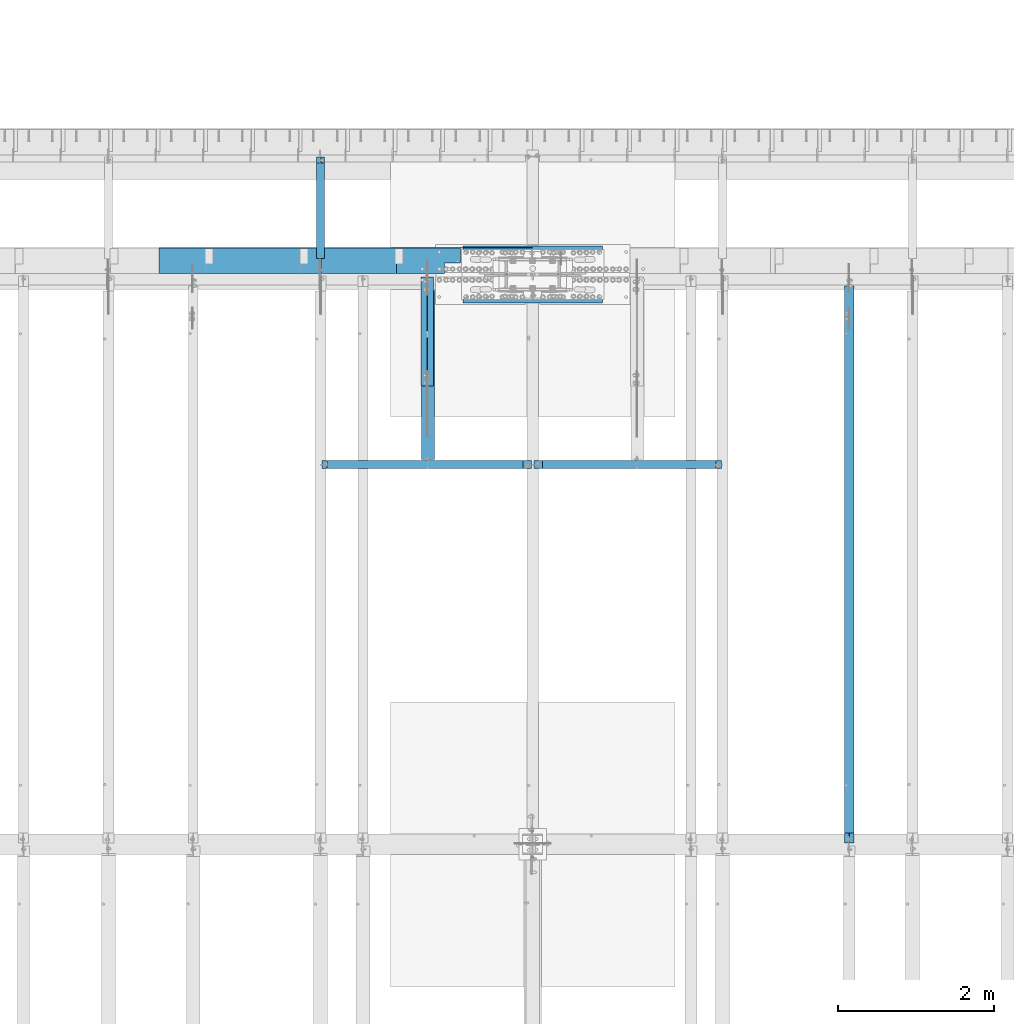
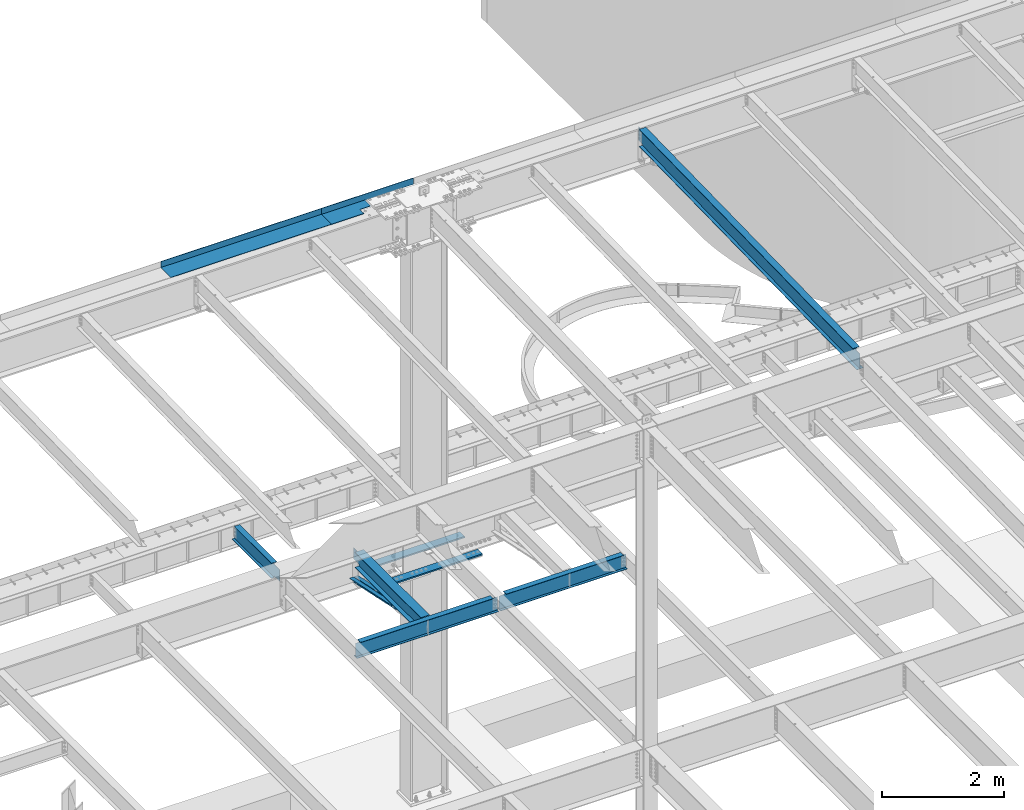
# One storey, part 1132 of 1763: 11 beams, 8 elements without a shape of their own.
"""IFC2X3 building model written with IfcOpenShell, lengths in millimetres."""

from ifc_helpers import new_model, si_unit, frame, origin_with_axes, place, context, subcontext, project, spatial, faceted_brep, material, type_object, element, aggregate, save


model = new_model("IFC2X3")

# Units and contexts
model_context = context("Model", 3, precision=1e-05, world=origin_with_axes())
body_context = subcontext(model_context, "Body", "Model", "MODEL_VIEW")
ifc_project = project(units=[si_unit("LENGTHUNIT", "METRE", prefix="MILLI"), si_unit("AREAUNIT", "SQUARE_METRE"), si_unit("VOLUMEUNIT", "CUBIC_METRE"), si_unit("MASSUNIT", "GRAM", prefix="KILO"), si_unit("TIMEUNIT", "SECOND"), si_unit("PLANEANGLEUNIT", "RADIAN"), si_unit("SOLIDANGLEUNIT", "STERADIAN"), si_unit("THERMODYNAMICTEMPERATUREUNIT", "DEGREE_CELSIUS"), si_unit("LUMINOUSINTENSITYUNIT", "LUMEN")], contexts=[model_context])

# Site, building, storey
site_placement = place(None, origin_with_axes())
site = spatial("IfcSite", under=ifc_project, at=site_placement, CompositionType="ELEMENT")
building_placement = place(site_placement, origin_with_axes())
building = spatial("IfcBuilding", under=site, at=building_placement, Name="Undefined", CompositionType="ELEMENT")
storey_placement = place(building_placement, origin_with_axes())
storey = spatial("IfcBuildingStorey", under=building, at=storey_placement, Name="Undefined", CompositionType="ELEMENT", Elevation=0.0)

# Assembly, beams
assembly_1_placement = place(storey_placement, origin_with_axes())
assembly_1 = element("IfcElementAssembly", 1, at=assembly_1_placement, inside=storey, Name="COLUMN", AssemblyPlace="NOTDEFINED", PredefinedType="RIGID_FRAME")
ifc_material_1 = material(Name="STEEL/A572-50")
beam_type_1 = type_object("IfcBeamType", PredefinedType="NOTDEFINED")
beam_1_placement = place(assembly_1_placement, frame((-60697.4997736983, 52409.725, 4433.8875), z_axis=(0.0, -1.0, 0.0), x_axis=(-1.0, 0.0, 0.0)))
beam_1 = element("IfcBeam", 2, at=beam_1_placement, type_object=beam_type_1, material=ifc_material_1, Name="PLATE", context=body_context, shape_type="Brep", body=[
    faceted_brep([(0.0, 14.2875000000004, -79.375), (0.0, 14.2875000000004, 79.375), (1793.875, 14.2875000000004, 79.375), (1793.875, 14.2875000000004, -79.375), (0.0, -14.2875000000004, 79.375), (1793.875, -14.2875000000004, 79.375), (0.0, -14.2875000000004, -79.375), (1793.875, -14.2875000000004, -79.375)], [[[0, 1, 2, 3]], [[1, 4, 5, 2]], [[4, 6, 7, 5]], [[6, 0, 3, 7]], [[5, 7, 3, 2]], [[6, 4, 1, 0]]]),
])
beam_2_placement = place(assembly_1_placement, frame((-60697.4997736983, 51831.875, 4433.8875), z_axis=(0.0, -1.0, 0.0), x_axis=(-1.0, 0.0, 0.0)))
beam_2 = element("IfcBeam", 3, at=beam_2_placement, type_object=beam_type_1, material=ifc_material_1, Name="PLATE", context=body_context, shape_type="Brep", body=[
    faceted_brep([(0.0, 14.2875000000004, -79.375), (0.0, 14.2875000000004, 79.375), (1793.875, 14.2875000000004, 79.375), (1793.875, 14.2875000000004, -79.375), (0.0, -14.2875000000004, 79.375), (1793.875, -14.2875000000004, 79.375), (0.0, -14.2875000000004, -79.375), (1793.875, -14.2875000000004, -79.375)], [[[0, 1, 2, 3]], [[1, 4, 5, 2]], [[4, 6, 7, 5]], [[6, 0, 3, 7]], [[5, 7, 3, 2]], [[6, 4, 1, 0]]]),
])
aggregate(assembly_1, [beam_1, beam_2])

# Assembly, beam
assembly_2_placement = place(storey_placement, origin_with_axes())
assembly_2 = element("IfcElementAssembly", 4, at=assembly_2_placement, inside=storey, Name="BEAM", AssemblyPlace="NOTDEFINED", PredefinedType="RIGID_FRAME")
ifc_material_2 = material(Name="STEEL/A992")
beam_type_2 = type_object("IfcBeamType", Name="W14X22", PredefinedType="NOTDEFINED")
beam_3_placement = place(assembly_2_placement, frame((-57530.4372736983, 44809.2121579121, 11421.5633921212), z_axis=(0.0, -0.0206852279954837, 0.999786037781472), x_axis=(0.0, 0.999786037781472, 0.0206852279954825)))
beam_3 = element("IfcBeam", 5, at=beam_3_placement, type_object=beam_type_2, material=ifc_material_2, Name="BEAM", ObjectType="W14X22", context=body_context, shape_type="Brep", body=[
    faceted_brep([(7162.77359555585, -3.17500000000291, -166.687500001777), (7162.77359555585, -63.5, -166.687500001777), (7162.77359555585, -63.5, -174.625000001772), (7162.77359555585, 63.5, -174.625000001772), (7162.77359555585, 63.5, -166.687500001777), (7162.77359555585, 3.17500000000291, -166.687500001777), (7162.77359555586, 3.17500000000291, -155.574999838074), (7162.77359555586, -3.17500000000291, -155.574999838074), (7163.74032547845, 3.17500000000291, -150.714920320039), (7163.74032547845, -3.17500000000291, -150.714920320039), (7166.49333937895, 3.17500000000291, -146.594743851894), (7166.49333937895, -3.17500000000291, -146.594743851894), (7170.61351584714, 3.17500000000291, -143.841729951426), (7170.61351584714, -3.17500000000291, -143.841729951426), (7175.47359536523, 3.17500000000291, -142.87500002884), (7175.47359536523, -3.17500000000291, -142.87500002884), (7289.55462988591, -3.17500000000291, -142.875000028898), (7289.55462988591, 3.17500000000291, -142.875000028898), (148.791145859177, 3.17500000000291, 166.687499999833), (148.791145859177, 63.5, 166.687499999833), (7169.123595556, 63.5, 166.68749999797), (7169.123595556, 3.17500000000291, 166.68749999797), (11.9924390219312, 3.17500000000291, -166.687499999878), (11.9924390219312, 63.5, -166.687499999878), (11.8282148869548, 63.5, -174.624999999871), (11.8282148869548, -63.5, -174.624999999871), (11.9924390219312, -63.5, -166.687499999878), (11.9924390219312, -3.17500000000291, -166.687499999878), (17.9976630864912, -3.17500000000291, 123.56500167838), (17.9976630864912, 3.17500000000291, 123.56500167838), (136.091146049795, -3.17500000000291, 123.565001678358), (136.091146049795, 3.17500000000291, 123.565001678358), (140.951225567893, -3.17500000000291, 124.531731600942), (140.951225567893, 3.17500000000291, 124.531731600942), (145.071402036083, -3.17500000000291, 127.284745501414), (145.071402036083, 3.17500000000291, 127.284745501414), (147.824415936586, -3.17500000000291, 131.404921969557), (147.824415936586, 3.17500000000291, 131.404921969557), (148.791145859177, -3.17500000000291, 136.265001487593), (148.791145859177, 3.17500000000291, 136.265001487593), (148.79114585917, -63.5, 174.624999999827), (148.79114585917, 63.5, 174.624999999827), (148.791145859177, -3.17500000000291, 166.687499999833), (148.791145859177, -63.5, 166.687499999833), (7169.123595556, -3.17500000000291, 166.68749999797), (7169.123595556, -63.5, 166.68749999797), (7169.123595556, -63.5, 174.624999997965), (7169.123595556, 63.5, 174.624999997965), (7169.123595556, -3.17500000000291, 142.875000542512), (7169.123595556, 3.17500000000291, 142.875000542512), (7170.0903254786, -3.17500000000291, 138.014921024478), (7170.0903254786, 3.17500000000291, 138.014921024478), (7172.8433393791, -3.17500000000291, 133.894744556334), (7172.8433393791, 3.17500000000291, 133.894744556334), (7176.96351584728, -3.17500000000291, 131.14173065586), (7176.96351584728, 3.17500000000291, 131.14173065586), (7181.82359536537, -3.17500000000291, 130.175000733272), (7181.82359536537, 3.17500000000291, 130.175000733272), (7295.20394014482, -3.17500000000291, 130.17500073325), (7295.20394014482, 3.17500000000291, 130.17500073325)], [[[0, 1, 2, 3, 4, 5, 6, 7]], [[7, 6, 8, 9]], [[9, 8, 10, 11]], [[11, 10, 12, 13]], [[13, 12, 14, 15]], [[16, 15, 14, 17]], [[18, 19, 20, 21]], [[22, 23, 24, 25, 26, 27, 28, 29]], [[30, 31, 29, 28]], [[32, 33, 31, 30]], [[34, 35, 33, 32]], [[36, 37, 35, 34]], [[38, 39, 37, 36]], [[40, 41, 19, 18, 39, 38, 42, 43]], [[43, 42, 44, 45]], [[40, 43, 45, 46]], [[41, 40, 46, 47]], [[19, 41, 47, 20]], [[46, 45, 44, 48, 49, 21, 20, 47]], [[50, 51, 49, 48]], [[52, 53, 51, 50]], [[54, 55, 53, 52]], [[56, 57, 55, 54]], [[58, 59, 57, 56]], [[59, 58, 16, 17]], [[12, 10, 8, 6, 5, 22, 29, 31, 33, 35, 37, 39, 18, 21, 49, 51, 53, 55, 57, 59, 17, 14]], [[23, 22, 5, 4]], [[24, 23, 4, 3]], [[25, 24, 3, 2]], [[26, 25, 2, 1]], [[27, 26, 1, 0]], [[58, 56, 54, 52, 50, 48, 44, 42, 38, 36, 34, 32, 30, 28, 27, 0, 7, 9, 11, 13, 15, 16]]]),
])
aggregate(assembly_2, [beam_3])

# Assembly, beams
assembly_3_placement = place(storey_placement, origin_with_axes())
assembly_3 = element("IfcElementAssembly", 6, at=assembly_3_placement, inside=storey, Name="ANGLE BRACE", AssemblyPlace="NOTDEFINED", PredefinedType="RIGID_FRAME")
ifc_material_3 = material(Name="STEEL/A36")
beam_type_3 = type_object("IfcBeamType", Name="L4X3X5/16", PredefinedType="NOTDEFINED")
beam_4_placement = place(assembly_3_placement, frame((-62991.4372736984, 50680.4564530846, 4820.75267554856), z_axis=(0.0, -0.2072236520035, -0.978293595016513), x_axis=(0.0, 0.978293600950479, -0.20722362398951)))
beam_4 = element("IfcBeam", 7, at=beam_4_placement, type_object=beam_type_3, material=ifc_material_3, Name="ANGLE BRACE", ObjectType="L4X3X5/16", context=body_context, shape_type="Brep", body=[
    faceted_brep([(1.45519152283669e-10, 38.0999999999985, -50.7999999999993), (1.45519152283669e-10, 38.0999999999985, 50.7999999999993), (1427.42255777739, 38.0999999999985, 50.7999999995518), (1427.42255777754, 38.0999999999985, -50.8000000004868), (-7.27595761418343e-11, 30.1624999999985, 50.8000000000211), (1427.42255777739, 30.1624999999985, 50.7999999995518), (7.27595761418343e-11, 30.1624999999985, -42.8625000000175), (1427.42255777754, 30.1624999999985, -42.8625000004868), (7.27595761418343e-11, -38.0999999999985, -42.8625000000175), (1427.42255777754, -38.0999999999985, -42.8625000004868), (-1.23691279441118e-10, -38.1000000000022, -50.7999999999993), (1427.42255777754, -38.0999999999985, -50.8000000004868)], [[[0, 1, 2, 3]], [[1, 4, 5, 2]], [[4, 6, 7, 5]], [[6, 8, 9, 7]], [[8, 10, 11, 9]], [[10, 0, 3, 11]], [[5, 7, 9, 11, 3, 2]], [[10, 8, 6, 4, 1, 0]]]),
])
beam_5_placement = place(assembly_3_placement, frame((-62905.7122736983, 52076.9355387112, 4524.94833056974), z_axis=(0.0, -0.2072236520035, -0.978293595016513), x_axis=(0.0, -0.978293595016513, 0.207223652003498)))
beam_5 = element("IfcBeam", 8, at=beam_5_placement, type_object=beam_type_3, material=ifc_material_3, Name="ANGLE BRACE", ObjectType="L4X3X5/16", context=body_context, shape_type="Brep", body=[
    faceted_brep([(1.45519152283669e-10, 38.0999999999985, -50.7999999999993), (1.45519152283669e-10, 38.0999999999985, 50.7999999999993), (1427.46422513096, 38.0999999999985, 50.7999999991189), (1427.46422513096, 38.0999999999985, -50.8000000008396), (-7.27595761418343e-11, 30.1624999999985, 50.8000000000211), (1427.46422513096, 30.1624999999985, 50.7999999991189), (7.27595761418343e-11, 30.1624999999985, -42.8625000000175), (1427.46422513096, 30.1624999999985, -42.8625000008433), (7.27595761418343e-11, -38.0999999999985, -42.8625000000175), (1427.46422513096, -38.0999999999985, -42.8625000008433), (-1.23691279441118e-10, -38.1000000000022, -50.7999999999993), (1427.46422513096, -38.0999999999985, -50.8000000008396)], [[[0, 1, 2, 3]], [[1, 4, 5, 2]], [[4, 6, 7, 5]], [[6, 8, 9, 7]], [[8, 10, 11, 9]], [[10, 0, 3, 11]], [[5, 7, 9, 11, 3, 2]], [[10, 8, 6, 4, 1, 0]]]),
])
aggregate(assembly_3, [beam_4, beam_5])

assembly_4_placement = place(storey_placement, origin_with_axes())
assembly_4 = element("IfcElementAssembly", 9, at=assembly_4_placement, inside=storey, Name="BEAM", AssemblyPlace="NOTDEFINED", PredefinedType="RIGID_FRAME")
beam_type_4 = type_object("IfcBeamType", PredefinedType="NOTDEFINED")
beam_6_placement = place(assembly_4_placement, frame((-62470.7372736983, 52133.5000002128, 11752.2624917654), z_axis=(-1.0, 0.0, 0.0), x_axis=(0.0, 1.0, 0.0)))
beam_6 = element("IfcBeam", 10, at=beam_6_placement, type_object=beam_type_4, material=ifc_material_3, Name="BENT_PLATE", context=body_context, shape_type="Brep", body=[
    faceted_brep([(0.0, -4.76250000000073, 255.587390624991), (0.0, 4.76250000000073, 255.587390624991), (133.349999999999, 4.76250000000073, 255.587390624991), (133.349999999999, -4.76250000000073, 255.587390624991), (133.349999999999, 4.76250000000073, 52.3875004882721), (133.349999999999, -4.76250000000073, 52.3875004882721), (327.02498779296, -4.76250000000073, 52.3865239257721), (327.02498779296, 4.76250000000073, 52.3865239257721), (327.024987792967, 4.76250000000073, -873.124499999998), (327.024987792975, -4.76250000000073, -873.124499999998), (336.549987792969, 4.76250000000073, 873.124499999998), (0.0, 4.76250000000073, 873.124499999998), (0.0, -4.76250000000073, 873.124499999998), (327.024987792975, -4.76250000000073, 873.124499999998), (327.024987792975, -122.237499999999, 873.124499999998), (336.549987792969, -122.237499999999, 873.124499999998), (336.549987792969, 4.76250000000073, -873.124499999998), (336.549987792969, -122.237499999999, -873.124499999998), (327.024987792975, -122.237499999999, -873.124499999998), (327.024987792975, -99.5375007629482, -873.124499999998)], [[[0, 1, 2, 3]], [[3, 2, 4, 5]], [[6, 7, 8, 9]], [[5, 4, 7, 6]], [[10, 11, 12, 13, 14, 15]], [[16, 10, 15, 17]], [[14, 18, 17, 15]], [[13, 6, 9, 19, 18, 14]], [[16, 17, 18, 19, 9, 8]], [[2, 1, 11, 10, 16, 8, 7, 4]], [[12, 11, 1, 0]], [[13, 12, 0, 3, 5, 6]]]),
])
beam_type_5 = type_object("IfcBeamType", PredefinedType="NOTDEFINED")
beam_7_placement = place(assembly_4_placement, frame((-64867.8617736983, 52133.5000002128, 11752.2624917654), z_axis=(-1.0, 0.0, 0.0), x_axis=(0.0, 1.0, 0.0)))
beam_7 = element("IfcBeam", 11, at=beam_7_placement, type_object=beam_type_5, material=ifc_material_3, Name="BENT_PLATE", context=body_context, shape_type="Brep", body=[
    faceted_brep([(0.0, -4.76249999999982, -1524.0), (0.0, -4.76249999999982, 1524.0), (0.0, 4.76249999999982, 1524.0), (0.0, 4.76249999999982, -1524.0), (336.549987792969, 4.76250000000073, 1524.0), (336.549987792969, 4.76250000000073, -1524.0), (327.024987792975, -4.76250000000073, -1524.0), (327.024987792967, -4.76250000000073, 1524.00000000001), (336.549987792969, -122.237499999999, 1524.0), (336.549987792969, -122.237499999999, -1524.0), (327.024987792975, -122.237499999999, 1524.0), (327.024987792975, -122.237499999999, -1524.0)], [[[0, 1, 2, 3]], [[3, 2, 4, 5]], [[1, 0, 6, 7]], [[5, 4, 8, 9]], [[4, 2, 1, 7, 10, 8]], [[7, 6, 11, 10]], [[6, 0, 3, 5, 9, 11]], [[10, 11, 9, 8]]]),
])
aggregate(assembly_4, [beam_6, beam_7])

# Assembly, beam
assembly_5_placement = place(storey_placement, origin_with_axes())
assembly_5 = element("IfcElementAssembly", 12, at=assembly_5_placement, inside=storey, Name="BEAM", AssemblyPlace="NOTDEFINED", PredefinedType="RIGID_FRAME")
beam_type_6 = type_object("IfcBeamType", Name="W12X16", PredefinedType="NOTDEFINED")
beam_8_placement = place(assembly_5_placement, frame((-64318.5872736984, 52120.8, 5041.9), z_axis=(0.0, 0.0, 1.0), x_axis=(0.0, 1.0, 0.0)))
beam_8 = element("IfcBeam", 13, at=beam_8_placement, type_object=beam_type_6, material=ifc_material_2, Name="BEAM", ObjectType="W12X16", context=body_context, shape_type="Brep", body=[
    faceted_brep([(20.6374999999971, -3.17500000000291, -114.3), (20.6374999999971, 3.17500000000291, -114.3), (192.087500190733, 3.17500000000291, -114.3), (192.087500190733, -3.17500000000291, -114.3), (196.94757970878, 3.17500000000291, -115.266729922588), (196.94757970878, -3.17500000000291, -115.266729922588), (201.067756176933, 3.17500000000291, -118.019743823066), (201.067756176933, -3.17500000000291, -118.019743823066), (203.820770077407, 3.17500000000291, -122.13992029122), (203.820770077407, -3.17500000000291, -122.13992029122), (204.787499999999, -3.17500000000291, -126.999999809265), (204.787499999999, 3.17500000000291, -126.999999809265), (204.787499999999, 3.17500000000291, -146.05), (204.787499999999, 50.8000000000029, -146.05), (204.787499999999, 50.8000000000029, -152.4), (204.787499999999, -50.8000000000029, -152.4), (204.787499999999, -50.8000000000029, -146.05), (204.787499999999, -3.17500000000291, -146.05), (1431.13125000001, 50.8000000000029, 146.05), (1431.13125000001, 3.17500000000291, 146.05), (204.787499999999, 3.17500000000291, 146.05), (204.787499999999, 50.8000000000029, 146.05), (192.087500190733, -3.17500000000291, 114.3), (192.087500190733, 3.17500000000291, 114.3), (20.6374999999971, 3.17500000000291, 114.3), (20.6374999999971, -3.17500000000291, 114.3), (196.94757970878, -3.17500000000291, 115.266729922588), (196.94757970878, 3.17500000000291, 115.266729922588), (201.067756176933, -3.17500000000291, 118.019743823066), (201.067756176933, 3.17500000000291, 118.019743823066), (203.820770077407, -3.17500000000291, 122.13992029122), (203.820770077407, 3.17500000000291, 122.13992029122), (204.787499999999, -3.17500000000291, 126.999999809265), (204.787499999999, 3.17500000000291, 126.999999809265), (1431.13125000001, -50.8000000000029, 152.4), (1431.13125000001, 50.8000000000029, 152.4), (204.787499999999, 50.8000000000029, 152.4), (204.787499999999, -50.8000000000029, 152.4), (1431.13125000001, -50.8000000000029, 146.05), (204.787499999999, -50.8000000000029, 146.05), (1431.13125000001, -3.17500000000291, 146.05), (204.787499999999, -3.17500000000291, 146.05), (1431.13125000001, -3.17500000000291, 139.440001487732), (1431.13125000001, 3.17500000000291, 139.440001487732), (1432.0979799226, -3.17500000000291, 134.579921969686), (1432.0979799226, 3.17500000000291, 134.579921969686), (1434.85099382307, -3.17500000000291, 130.459745501533), (1434.85099382307, 3.17500000000291, 130.459745501533), (1438.97117029122, -3.17500000000291, 127.706731601054), (1438.97117029122, 3.17500000000291, 127.706731601054), (1443.83124980927, -3.17500000000291, 126.740001678467), (1443.83124980927, 3.17500000000291, 126.740001678467), (1507.33125, -3.17500000000291, 126.740001678467), (1507.33125, 3.17500000000291, 126.740001678467), (1507.33125, -3.17500000000291, -146.05), (1507.33125, -50.8000000000029, -146.05), (1507.33125, -50.8000000000029, -152.4), (1507.33125, 50.8000000000029, -152.4), (1507.33125, 50.8000000000029, -146.05), (1507.33125, 3.17500000000291, -146.05)], [[[0, 1, 2, 3]], [[3, 2, 4, 5]], [[5, 4, 6, 7]], [[7, 6, 8, 9]], [[10, 11, 12, 13, 14, 15, 16, 17]], [[9, 8, 11, 10]], [[18, 19, 20, 21]], [[22, 23, 24, 25]], [[26, 27, 23, 22]], [[28, 29, 27, 26]], [[30, 31, 29, 28]], [[32, 33, 31, 30]], [[34, 35, 36, 37]], [[38, 34, 37, 39]], [[40, 38, 39, 41]], [[37, 36, 21, 20, 33, 32, 41, 39]], [[35, 18, 21, 36]], [[34, 38, 40, 42, 43, 19, 18, 35]], [[44, 45, 43, 42]], [[46, 47, 45, 44]], [[48, 49, 47, 46]], [[50, 51, 49, 48]], [[52, 53, 51, 50]], [[54, 55, 56, 57, 58, 59, 53, 52]], [[55, 54, 17, 16]], [[56, 55, 16, 15]], [[57, 56, 15, 14]], [[58, 57, 14, 13]], [[59, 58, 13, 12]], [[6, 4, 2, 1, 24, 23, 27, 29, 31, 33, 20, 19, 43, 45, 47, 49, 51, 53, 59, 12, 11, 8]], [[25, 24, 1, 0]], [[54, 52, 50, 48, 46, 44, 42, 40, 41, 32, 30, 28, 26, 22, 25, 0, 3, 5, 7, 9, 10, 17]]]),
])
aggregate(assembly_5, [beam_8])

assembly_6_placement = place(storey_placement, origin_with_axes())
assembly_6 = element("IfcElementAssembly", 14, at=assembly_6_placement, inside=storey, Name="BEAM", AssemblyPlace="NOTDEFINED", PredefinedType="RIGID_FRAME")
beam_type_7 = type_object("IfcBeamType", Name="W12X26", PredefinedType="NOTDEFINED")
beam_9_placement = place(assembly_6_placement, frame((-62940.6372736983, 49682.4, 5038.725), z_axis=(0.0, 0.0, 1.0), x_axis=(0.0, 1.0, 0.0)))
beam_9 = element("IfcBeam", 15, at=beam_9_placement, type_object=beam_type_7, material=ifc_material_2, Name="BEAM", ObjectType="W12X26", context=body_context, shape_type="Brep", body=[
    faceted_brep([(2233.6125, -3.17500000000291, -146.05), (2233.6125, -82.5500000000029, -146.05), (2233.6125, -82.5500000000029, -155.575), (2233.6125, 82.5500000000029, -155.575), (2233.6125, 82.5500000000029, -146.05), (2233.6125, 3.17500000000291, -146.05), (2233.6125, 3.17500000000291, -123.824999809265), (2233.6125, -3.17500000000291, -123.824999809265), (2234.57922992259, 3.17500000000291, -118.96492029122), (2234.57922992259, -3.17500000000291, -118.96492029122), (2237.33224382307, 3.17500000000291, -114.844743823066), (2237.33224382307, -3.17500000000291, -114.844743823066), (2241.45242029122, 3.17500000000291, -112.091729922588), (2241.45242029122, -3.17500000000291, -112.091729922588), (2246.31249980927, 3.17500000000291, -111.125), (2246.31249980927, -3.17500000000291, -111.125), (2417.7625, -3.17500000000291, -111.125), (2417.7625, 3.17500000000291, -111.125), (65.8812499999913, 3.17500000000291, 146.05), (65.8812499999913, 82.5500000000029, 146.05), (2233.6125, 82.5500000000029, 146.05), (2233.6125, 3.17500000000291, 146.05), (65.8812499999913, -3.17500000000291, -123.824999809265), (65.8812499999913, 3.17500000000291, -123.824999809265), (65.8812499999913, 3.17500000000291, -146.05), (65.8812499999913, 82.5500000000029, -146.05), (65.8812499999913, 82.5500000000029, -155.575), (65.8812499999913, -82.5500000000029, -155.575), (65.8812499999913, -82.5500000000029, -146.05), (65.8812499999913, -3.17500000000291, -146.05), (64.9145200774001, -3.17500000000291, -118.96492029122), (64.9145200774001, 3.17500000000291, -118.96492029122), (62.1615061769262, -3.17500000000291, -114.844743823066), (62.1615061769262, 3.17500000000291, -114.844743823066), (58.0413297087725, -3.17500000000291, -112.091729922588), (58.0413297087725, 3.17500000000291, -112.091729922588), (53.1812501907261, -3.17500000000291, -111.125), (53.1812501907261, 3.17500000000291, -111.125), (15.0812499999956, -3.17500000000291, -111.125), (15.0812499999956, 3.17500000000291, -111.125), (15.0812499999956, -3.17500000000291, 117.475), (15.0812499999956, 3.17500000000291, 117.475), (53.1812501907261, -3.17500000000291, 117.475), (53.1812501907261, 3.17500000000291, 117.475), (58.0413297087725, -3.17500000000291, 118.441729922588), (58.0413297087725, 3.17500000000291, 118.441729922588), (62.1615061769262, -3.17500000000291, 121.194743823066), (62.1615061769262, 3.17500000000291, 121.194743823066), (64.9145200774001, -3.17500000000291, 125.31492029122), (64.9145200774001, 3.17500000000291, 125.31492029122), (65.8812499999913, -3.17500000000291, 130.174999809266), (65.8812499999913, 3.17500000000291, 130.174999809266), (65.8812499999913, -82.5500000000029, 155.575), (65.8812499999913, 82.5500000000029, 155.575), (65.8812499999913, -3.17500000000291, 146.05), (65.8812499999913, -82.5500000000029, 146.05), (2233.6125, -3.17500000000291, 146.05), (2233.6125, -82.5500000000029, 146.05), (2233.6125, -82.5500000000029, 155.575), (2233.6125, 82.5500000000029, 155.575), (2233.6125, -3.17500000000291, 123.824999809265), (2233.6125, 3.17500000000291, 123.824999809265), (2234.57922992259, -3.17500000000291, 118.96492029122), (2234.57922992259, 3.17500000000291, 118.96492029122), (2237.33224382307, -3.17500000000291, 114.844743823066), (2237.33224382307, 3.17500000000291, 114.844743823066), (2241.45242029122, -3.17500000000291, 112.091729922588), (2241.45242029122, 3.17500000000291, 112.091729922588), (2246.31249980927, -3.17500000000291, 111.125), (2246.31249980927, 3.17500000000291, 111.125), (2417.7625, -3.17500000000291, 111.125), (2417.7625, 3.17500000000291, 111.125)], [[[0, 1, 2, 3, 4, 5, 6, 7]], [[7, 6, 8, 9]], [[9, 8, 10, 11]], [[11, 10, 12, 13]], [[13, 12, 14, 15]], [[16, 15, 14, 17]], [[18, 19, 20, 21]], [[22, 23, 24, 25, 26, 27, 28, 29]], [[30, 31, 23, 22]], [[32, 33, 31, 30]], [[34, 35, 33, 32]], [[36, 37, 35, 34]], [[38, 39, 37, 36]], [[40, 41, 39, 38]], [[42, 43, 41, 40]], [[44, 45, 43, 42]], [[46, 47, 45, 44]], [[48, 49, 47, 46]], [[50, 51, 49, 48]], [[52, 53, 19, 18, 51, 50, 54, 55]], [[55, 54, 56, 57]], [[52, 55, 57, 58]], [[53, 52, 58, 59]], [[19, 53, 59, 20]], [[58, 57, 56, 60, 61, 21, 20, 59]], [[62, 63, 61, 60]], [[64, 65, 63, 62]], [[66, 67, 65, 64]], [[68, 69, 67, 66]], [[70, 71, 69, 68]], [[71, 70, 16, 17]], [[12, 10, 8, 6, 5, 24, 23, 31, 33, 35, 37, 39, 41, 43, 45, 47, 49, 51, 18, 21, 61, 63, 65, 67, 69, 71, 17, 14]], [[25, 24, 5, 4]], [[26, 25, 4, 3]], [[27, 26, 3, 2]], [[28, 27, 2, 1]], [[29, 28, 1, 0]], [[70, 68, 66, 64, 62, 60, 56, 54, 50, 48, 46, 44, 42, 40, 38, 36, 34, 32, 30, 22, 29, 0, 7, 9, 11, 13, 15, 16]]]),
])
aggregate(assembly_6, [beam_9])

assembly_7_placement = place(storey_placement, origin_with_axes())
assembly_7 = element("IfcElementAssembly", 16, at=assembly_7_placement, inside=storey, Name="BEAM", AssemblyPlace="NOTDEFINED", PredefinedType="RIGID_FRAME")
beam_type_8 = type_object("IfcBeamType", Name="W12X14", PredefinedType="NOTDEFINED")
beam_10_placement = place(assembly_7_placement, frame((-61594.4372736983, 49682.4, 5043.4875), z_axis=(0.0, 0.0, 1.0), x_axis=(1.0, 0.0, 0.0)))
beam_10 = element("IfcBeam", 17, at=beam_10_placement, type_object=beam_type_8, material=ifc_material_2, Name="BEAM", ObjectType="W12X14", context=body_context, shape_type="Brep", body=[
    faceted_brep([(111.918750190736, -2.38124999999854, 118.802501678467), (111.918750190736, 2.38124999999854, 118.802501678467), (16.6687499999971, 2.38124999999854, 118.802501678467), (16.6687499999971, -2.38124999999854, 118.802501678467), (116.778829708783, -2.38124999999854, 119.769231601054), (116.778829708783, 2.38124999999854, 119.769231601054), (120.899006176936, -2.38124999999854, 122.522245501533), (120.899006176936, 2.38124999999854, 122.522245501533), (123.65202007741, -2.38124999999854, 126.642421969686), (123.65202007741, 2.38124999999854, 126.642421969686), (124.618750000001, -2.38124999999854, 131.502501487732), (124.618750000001, 2.38124999999854, 131.502501487732), (124.618750000001, -50.8000000000029, 150.8125), (124.618750000001, 50.8000000000029, 150.8125), (124.618750000001, 50.8000000000029, 144.4625), (124.618750000001, 2.38124999999854, 144.4625), (124.618750000001, -2.38124999999854, 144.4625), (124.618750000001, -50.8000000000029, 144.4625), (16.6687499999971, -2.38124999999854, -144.4625), (16.6687499999898, -50.7999999999993, -144.4625), (2422.525, -50.8000000000029, -144.4625), (2422.525, -2.38124999999854, -144.4625), (16.6687499999971, -50.8000000000029, -150.8125), (2422.525, -50.8000000000029, -150.8125), (16.6687499999971, 50.8000000000029, -150.8125), (2422.525, 50.8000000000029, -150.8125), (16.6687499999898, 50.7999999999993, -144.4625), (2422.525, 50.8000000000029, -144.4625), (16.6687499999971, 2.38124999999854, -144.4625), (2422.525, 2.38124999999854, -144.4625), (2422.525, 2.38124999999854, 125.152501678466), (2422.525, -2.38124999999854, 125.152501678466), (2365.37499980927, 2.38124999999854, 125.152501678466), (2365.37499980927, -2.38124999999854, 125.152501678466), (2360.51492029122, 2.38124999999854, 126.119231601054), (2360.51492029122, -2.38124999999854, 126.119231601054), (2356.39474382307, 2.38124999999854, 128.872245501532), (2356.39474382307, -2.38124999999854, 128.872245501532), (2353.64172992259, 2.38124999999854, 132.992421969686), (2353.64172992259, -2.38124999999854, 132.992421969686), (2352.675, 2.38124999999854, 137.852501487731), (2352.675, -2.38124999999854, 137.852501487731), (2352.675, -50.8000000000029, 150.8125), (2352.675, -50.8000000000029, 144.4625), (2352.675, -2.38124999999854, 144.4625), (2352.675, 2.38124999999854, 144.4625), (2352.675, 50.8000000000029, 144.4625), (2352.675, 50.8000000000029, 150.8125)], [[[0, 1, 2, 3]], [[4, 5, 1, 0]], [[6, 7, 5, 4]], [[8, 9, 7, 6]], [[10, 11, 9, 8]], [[12, 13, 14, 15, 11, 10, 16, 17]], [[18, 19, 20, 21]], [[19, 22, 23, 20]], [[22, 24, 25, 23]], [[24, 26, 27, 25]], [[26, 28, 29, 27]], [[21, 20, 23, 25, 27, 29, 30, 31]], [[31, 30, 32, 33]], [[33, 32, 34, 35]], [[35, 34, 36, 37]], [[37, 36, 38, 39]], [[39, 38, 40, 41]], [[42, 43, 44, 41, 40, 45, 46, 47]], [[43, 42, 12, 17]], [[44, 43, 17, 16]], [[8, 6, 4, 0, 3, 18, 21, 31, 33, 35, 37, 39, 41, 44, 16, 10]], [[28, 26, 24, 22, 19, 18, 3, 2]], [[45, 40, 38, 36, 34, 32, 30, 29, 28, 2, 1, 5, 7, 9, 11, 15]], [[46, 45, 15, 14]], [[47, 46, 14, 13]], [[42, 47, 13, 12]]]),
])
aggregate(assembly_7, [beam_10])

assembly_8_placement = place(storey_placement, origin_with_axes())
assembly_8 = element("IfcElementAssembly", 18, at=assembly_8_placement, inside=storey, Name="BEAM", AssemblyPlace="NOTDEFINED", PredefinedType="RIGID_FRAME")
beam_11_placement = place(assembly_8_placement, frame((-64318.5872736984, 49682.4, 5043.4875), z_axis=(0.0, 0.0, 1.0), x_axis=(1.0, 0.0, 0.0)))
beam_11 = element("IfcBeam", 19, at=beam_11_placement, type_object=beam_type_8, material=ifc_material_2, Name="BEAM", ObjectType="W12X14", context=body_context, shape_type="Brep", body=[
    faceted_brep([(2599.53125000001, -50.8000000000029, 150.8125), (2599.53125000001, -50.8000000000029, 144.4625), (2599.53125000001, -2.38124999999854, 144.4625), (2599.53125000001, -2.38124999999854, 131.502501487732), (2599.53125000001, 2.38124999999854, 131.502501487732), (2599.53125000001, 2.38124999999854, 144.4625), (2599.53125000001, 50.8000000000029, 144.4625), (2599.53125000001, 50.8000000000029, 150.8125), (2600.4979799226, -2.38124999999854, 126.642421969686), (2600.4979799226, 2.38124999999854, 126.642421969686), (2603.25099382307, -2.38124999999854, 122.522245501533), (2603.25099382307, 2.38124999999854, 122.522245501533), (2607.37117029123, -2.38124999999854, 119.769231601054), (2607.37117029123, 2.38124999999854, 119.769231601054), (2612.23124980927, -2.38124999999854, 118.802501678467), (2612.23124980927, 2.38124999999854, 118.802501678467), (2707.48125, -2.38124999999854, 118.802501678467), (2707.48125, 2.38124999999854, 118.802501678467), (85.724999999984, -50.8000000000029, 150.8125), (85.724999999984, 50.8000000000029, 150.8125), (85.724999999984, 50.8000000000029, 144.4625), (85.724999999984, 2.38124999999854, 144.4625), (85.724999999984, 2.38124999999854, 137.852501487731), (85.724999999984, -2.38124999999854, 137.852501487731), (85.724999999984, -2.38124999999854, 144.4625), (85.724999999984, -50.8000000000029, 144.4625), (84.7582700773928, 2.38124999999854, 132.992421969686), (84.7582700773928, -2.38124999999854, 132.992421969686), (82.0052561769189, 2.38124999999854, 128.872245501532), (82.0052561769189, -2.38124999999854, 128.872245501532), (77.8850797087653, 2.38124999999854, 126.119231601054), (77.8850797087653, -2.38124999999854, 126.119231601054), (73.0250001907189, 2.38124999999854, 125.152501678466), (73.0250001907189, -2.38124999999854, 125.152501678466), (15.875, 2.38124999999854, 125.152501678466), (15.875, -2.38124999999854, 125.152501678466), (15.875, 2.38124999999854, -144.4625), (15.875, 50.8000000000029, -144.4625), (15.875, 50.8000000000029, -150.8125), (15.875, -50.8000000000029, -150.8125), (15.875, -50.8000000000029, -144.4625), (15.875, -2.38124999999854, -144.4625), (2707.48125, 2.38124999999854, -144.4625), (2707.48125, 50.8000000000029, -144.4625), (2707.48125, 50.8000000000029, -150.8125), (2707.48125, -50.8000000000029, -150.8125), (2707.48125, -50.8000000000029, -144.4625), (2707.48125, -2.38124999999854, -144.4625)], [[[0, 1, 2, 3, 4, 5, 6, 7]], [[8, 9, 4, 3]], [[10, 11, 9, 8]], [[12, 13, 11, 10]], [[14, 15, 13, 12]], [[16, 17, 15, 14]], [[18, 19, 20, 21, 22, 23, 24, 25]], [[23, 22, 26, 27]], [[27, 26, 28, 29]], [[29, 28, 30, 31]], [[31, 30, 32, 33]], [[33, 32, 34, 35]], [[36, 37, 38, 39, 40, 41, 35, 34]], [[37, 36, 42, 43]], [[38, 37, 43, 44]], [[39, 38, 44, 45]], [[40, 39, 45, 46]], [[41, 40, 46, 47]], [[12, 10, 8, 3, 2, 24, 23, 27, 29, 31, 33, 35, 41, 47, 16, 14]], [[25, 24, 2, 1]], [[18, 25, 1, 0]], [[19, 18, 0, 7]], [[20, 19, 7, 6]], [[21, 20, 6, 5]], [[42, 36, 34, 32, 30, 28, 26, 22, 21, 5, 4, 9, 11, 13, 15, 17]], [[47, 46, 45, 44, 43, 42, 17, 16]]]),
])
aggregate(assembly_8, [beam_11])

save(model, "model.ifc")
